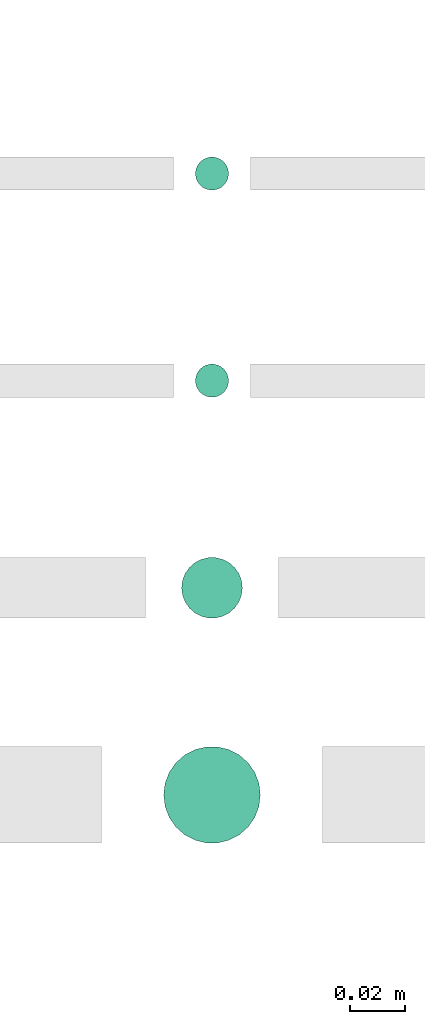
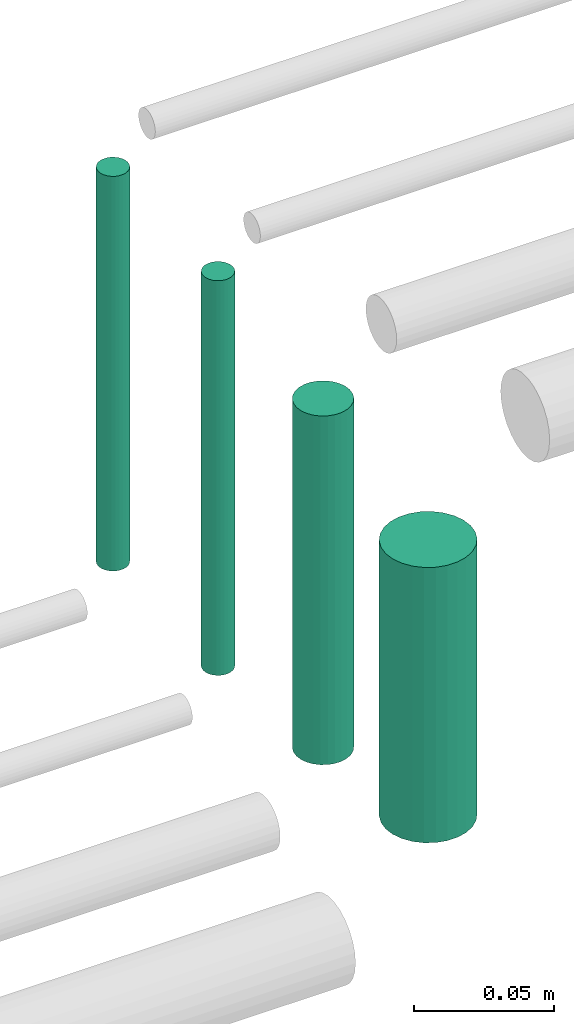
# One storey, part 158 of 331: 4 flow segments.
"""IFC2X3 building model written with IfcOpenShell, lengths in millimetres."""

from ifc_helpers import new_model, entity, si_unit, converted_unit, derived_unit, direction, frame, origin, origin_2d_with_axis, place, context, subcontext, project, spatial, circle, extrude, type_object, element, save


model = new_model("IFC2X3")

# Units and contexts
model_context = context("Model", 3, precision=0.01, world=origin(), true_north=direction((6.12303176911189e-17, 1.0)))
body_context = subcontext(model_context, "Body", "Model", "MODEL_VIEW")
ifc_project = project(units=[si_unit("LENGTHUNIT", "METRE", prefix="MILLI"), si_unit("AREAUNIT", "SQUARE_METRE"), si_unit("VOLUMEUNIT", "CUBIC_METRE"), converted_unit("PLANEANGLEUNIT", "DEGREE", entity("IfcRatioMeasure", 0.0174532925199433), si_unit("PLANEANGLEUNIT", "RADIAN"), dimensions=[0, 0, 0, 0, 0, 0, 0]), si_unit("MASSUNIT", "GRAM", prefix="KILO"), derived_unit("MASSDENSITYUNIT", [(si_unit("MASSUNIT", "GRAM", prefix="KILO"), 1), (si_unit("LENGTHUNIT", "METRE"), -3)]), derived_unit("MOMENTOFINERTIAUNIT", [(si_unit("LENGTHUNIT", "METRE"), 4)]), si_unit("TIMEUNIT", "SECOND"), si_unit("FREQUENCYUNIT", "HERTZ"), si_unit("THERMODYNAMICTEMPERATUREUNIT", "DEGREE_CELSIUS"), derived_unit("THERMALTRANSMITTANCEUNIT", [(si_unit("MASSUNIT", "GRAM", prefix="KILO"), 1), (si_unit("THERMODYNAMICTEMPERATUREUNIT", "KELVIN"), -1), (si_unit("TIMEUNIT", "SECOND"), -3)]), derived_unit("VOLUMETRICFLOWRATEUNIT", [(si_unit("LENGTHUNIT", "METRE"), 3), (si_unit("TIMEUNIT", "SECOND"), -1)]), derived_unit("MASSFLOWRATEUNIT", [(si_unit("MASSUNIT", "GRAM", prefix="KILO"), 1), (si_unit("TIMEUNIT", "SECOND"), -1)]), derived_unit("ROTATIONALFREQUENCYUNIT", [(si_unit("TIMEUNIT", "SECOND"), -1)]), si_unit("ELECTRICCURRENTUNIT", "AMPERE"), si_unit("ELECTRICVOLTAGEUNIT", "VOLT"), si_unit("POWERUNIT", "WATT"), si_unit("FORCEUNIT", "NEWTON", prefix="KILO"), si_unit("ILLUMINANCEUNIT", "LUX"), si_unit("LUMINOUSFLUXUNIT", "LUMEN"), si_unit("LUMINOUSINTENSITYUNIT", "CANDELA"), derived_unit("USERDEFINED", [(si_unit("MASSUNIT", "GRAM", prefix="KILO"), -1), (si_unit("LENGTHUNIT", "METRE"), -2), (si_unit("TIMEUNIT", "SECOND"), 3), (si_unit("LUMINOUSFLUXUNIT", "LUMEN"), 1)]), derived_unit("LINEARVELOCITYUNIT", [(si_unit("LENGTHUNIT", "METRE"), 1), (si_unit("TIMEUNIT", "SECOND"), -1)]), si_unit("PRESSUREUNIT", "PASCAL"), derived_unit("USERDEFINED", [(si_unit("LENGTHUNIT", "METRE"), -2), (si_unit("MASSUNIT", "GRAM", prefix="KILO"), 1), (si_unit("TIMEUNIT", "SECOND"), -2)]), derived_unit("LINEARFORCEUNIT", [(si_unit("MASSUNIT", "GRAM", prefix="KILO"), 1), (si_unit("LENGTHUNIT", "METRE"), 1), (si_unit("TIMEUNIT", "SECOND"), -2), (si_unit("LENGTHUNIT", "METRE"), -1)]), derived_unit("PLANARFORCEUNIT", [(si_unit("MASSUNIT", "GRAM", prefix="KILO"), 1), (si_unit("LENGTHUNIT", "METRE"), 1), (si_unit("TIMEUNIT", "SECOND"), -2), (si_unit("LENGTHUNIT", "METRE"), -2)])], contexts=[model_context])

# Site, building, storey
site_placement = place(None, frame((0.0, -0.00077364408347762, 0.0)))
site = spatial("IfcSite", under=ifc_project, at=site_placement, CompositionType="ELEMENT")
building_placement = place(site_placement, origin())
building = spatial("IfcBuilding", under=site, at=building_placement, CompositionType="ELEMENT")
storey_placement = place(building_placement, origin())
storey = spatial("IfcBuildingStorey", under=building, at=storey_placement, CompositionType="ELEMENT", Elevation=0.0)

# Flow segments
pipe_segment_type = type_object("IfcPipeSegmentType", PredefinedType="NOTDEFINED")
flow_segment_1_placement = place(storey_placement, frame((34988.4852792261, 8668.02529159148, 14564.0)))
element("IfcFlowSegment", 1, at=flow_segment_1_placement, inside=storey, type_object=pipe_segment_type, context=body_context, shape_type="SweptSolid", body=[
    extrude(circle(Radius=6.0, at=origin_2d_with_axis()), frame((7.59527223591454, 7.59527223591562, 0.0), z_axis=(0.0, 0.0, 1.0), x_axis=(-1.0, 0.0, 0.0)), (0.0, 0.0, 1.0), 172.000000000048),
])
flow_segment_2_placement = place(storey_placement, frame((34988.4852792261, 8593.02529159148, 14564.0)))
element("IfcFlowSegment", 2, at=flow_segment_2_placement, inside=storey, type_object=pipe_segment_type, context=body_context, shape_type="SweptSolid", body=[
    extrude(circle(Radius=6.0, at=origin_2d_with_axis()), frame((7.59527223591454, 7.59527223591562, 0.0), z_axis=(0.0, 0.0, 1.0), x_axis=(-1.0, 0.0, 0.0)), (0.0, 0.0, 1.0), 172.000000000024),
])
flow_segment_3_placement = place(storey_placement, frame((34983.4852792261, 8513.02529159146, 14574.0)))
element("IfcFlowSegment", 3, at=flow_segment_3_placement, inside=storey, type_object=pipe_segment_type, context=body_context, shape_type="SweptSolid", body=[
    extrude(circle(Radius=11.0, at=origin_2d_with_axis()), frame((12.5952722359177, 12.5952722359156, 0.0), z_axis=(0.0, 0.0, 1.0), x_axis=(-1.0, 0.0, 0.0)), (0.0, 0.0, 1.0), 152.000000000026),
])
flow_segment_4_placement = place(storey_placement, frame((34976.9852792261, 8431.52529159144, 14590.0)))
element("IfcFlowSegment", 4, at=flow_segment_4_placement, inside=storey, type_object=pipe_segment_type, context=body_context, shape_type="SweptSolid", body=[
    extrude(circle(Radius=17.5, at=origin_2d_with_axis()), frame((19.0952722359163, 19.0952722359163, 0.0), z_axis=(0.0, 0.0, 1.0), x_axis=(-1.0, 0.0, 0.0)), (0.0, 0.0, 1.0), 120.000000000053),
])

save(model, "model.ifc")
